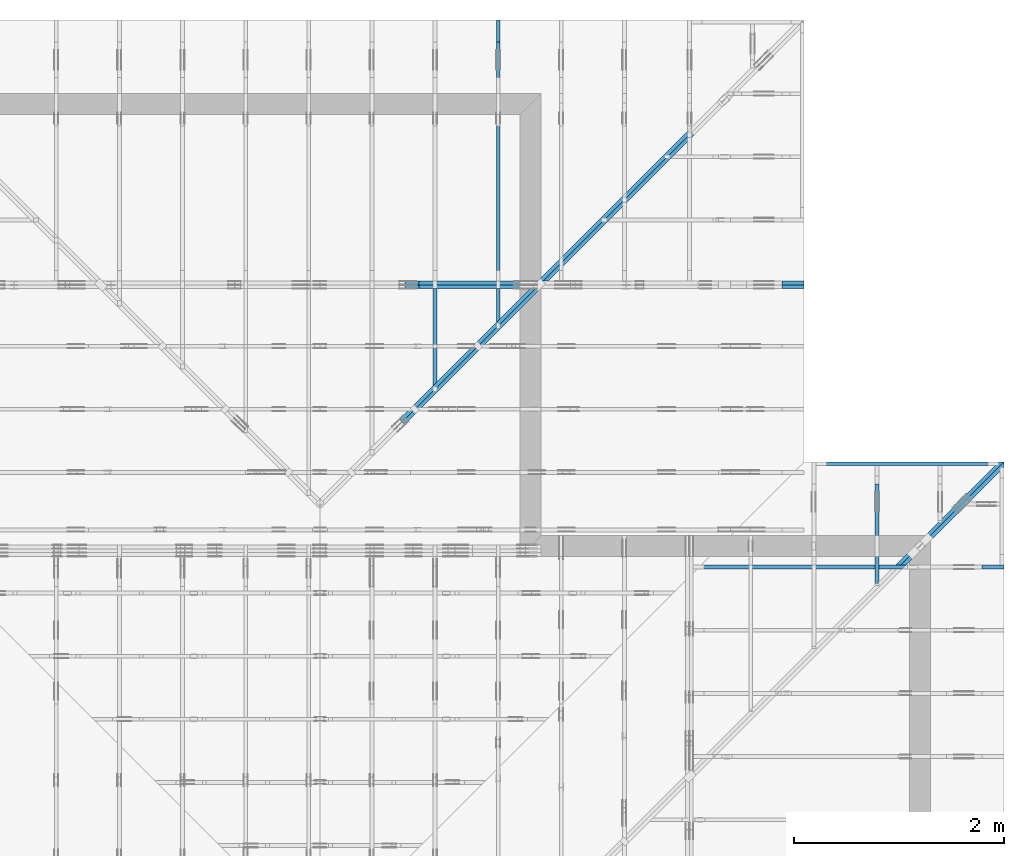
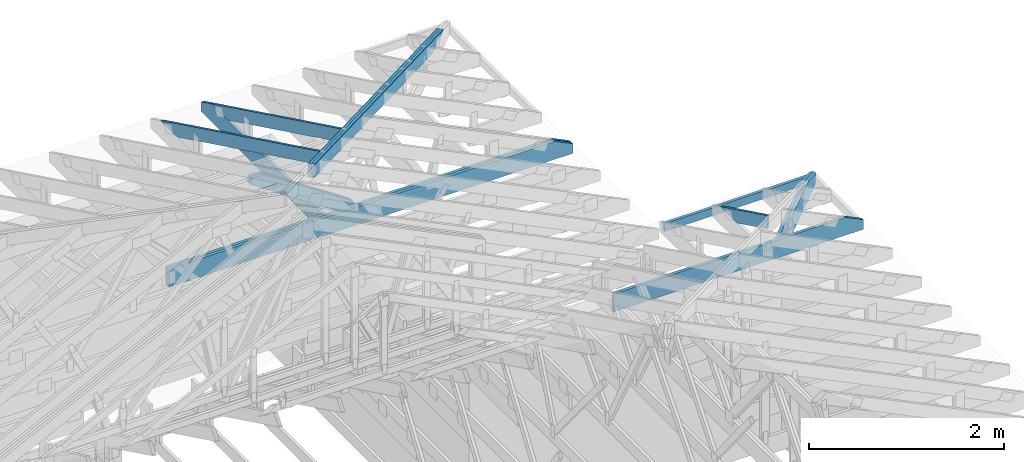
# One storey, part 39 of 159: 14 members, 8 elements without a shape of their own.
"""IFC2X3 building model written with IfcOpenShell, lengths in millimetres."""

from ifc_helpers import new_model, si_unit, frame, origin, origin_with_axes, origin_2d, place, context, project, spatial, faceted_brep, element, aggregate, save


model = new_model("IFC2X3")

# Units and contexts
model_context = context("Model", 3, precision=1e-05, world=origin())
plan_context = context("Plan", 2, precision=1e-05, world=origin_2d())
ifc_project = project(units=[si_unit("LENGTHUNIT", "METRE", prefix="MILLI"), si_unit("AREAUNIT", "SQUARE_METRE"), si_unit("VOLUMEUNIT", "CUBIC_METRE"), si_unit("SOLIDANGLEUNIT", "STERADIAN"), si_unit("PLANEANGLEUNIT", "RADIAN"), si_unit("MASSUNIT", "GRAM"), si_unit("TIMEUNIT", "SECOND"), si_unit("THERMODYNAMICTEMPERATUREUNIT", "DEGREE_CELSIUS"), si_unit("LUMINOUSINTENSITYUNIT", "LUMEN")], contexts=[model_context, plan_context])

# Site, building, storey
site_placement = place(None, origin_with_axes())
site = spatial("IfcSite", under=ifc_project, at=site_placement, CompositionType="ELEMENT")
building_placement = place(site_placement, origin_with_axes())
building = spatial("IfcBuilding", under=site, at=building_placement, Name="Plan 1", CompositionType="ELEMENT")
storey_placement = place(building_placement, origin_with_axes())
storey = spatial("IfcBuildingStorey", under=building, at=storey_placement, Name="Etasje 1", CompositionType="ELEMENT", Elevation=0.0)

# Assembly, member
assembly_1_placement = place(storey_placement, frame((19875.02226140475, 9663.999999999993, 1.1021457184401395e-15), z_axis=(-1.0, 1.836909530733566e-16, 6.123031769111886e-17), x_axis=(-1.836909530733566e-16, -1.0, 0.0)))
assembly_1 = element("IfcElementAssembly", 1, at=assembly_1_placement, inside=storey, Name="S22 (57)", AssemblyPlace="FACTORY", PredefinedType="TRUSS")
member_1_placement = place(assembly_1_placement, frame((240.0602225673573, 89.97847976245569, -36.000000217775856), z_axis=(0.0, 0.0, 1.0), x_axis=(0.898794046299167, 0.4383711467890774, 0.0)))
member_1 = element("IfcMember", 2, at=member_1_placement, Name="S22-O69", context=model_context, shape_type="Brep", body=[
    faceted_brep([(1071.3215394906892, 147.99999481755967, 36.00000324764591), (999.1371155399152, 7.034373084024992e-10, 36.000000217775664), (959.083445597556, 3.216400443761813e-07, -2.2737367544323206e-13), (1031.2678695483298, 147.99999513849625, 3.0298697311081924e-06), (5.444185688929792e-06, 147.99999999998226, 2.1777585601512328e-07), (5.444185688929792e-06, 147.9999999999822, 36.000000217775856), (1071.3215386473107, 147.99999999998215, 36.000000217775856), (1031.2678696714806, 147.9999999999822, 2.1777585601512328e-07), (4.652508783919984e-05, 148.00000000045958, 2.1777585601512897e-07), (1031.2678687907128, 148.00000000045958, 2.1777598230484175e-07), (959.083443436709, 0.0, 2.1777597346509114e-07), (303.4449928141504, 0.0, 2.177758931751899e-07), (303.4449717131313, 3.1174351988738636e-10, 2.1777585601512328e-07), (303.4449717131313, 3.1174351988738636e-10, 36.000000217775856), (7.105427357601002e-15, 148.000001541252, 36.000000217775856), (7.105427357601002e-15, 148.000001541252, 2.1777585601512328e-07), (999.1371146591276, 6.808444057420046e-10, 36.000000217775856), (303.4449569137662, 6.809721980975065e-10, 36.000000217775856), (303.4449569137662, 6.809699938060696e-10, 2.1777585601512328e-07), (959.0834456832976, 6.808495589471959e-10, 2.1777585601512328e-07), (1071.321540893919, 148.0000000007036, 36.000000217775856), (3.057897757230421e-05, 148.0000000007036, 36.000000217775856), (303.44497686804016, 3.1187141757982317e-10, 36.000000217775856), (999.137115539915, 3.1187141757982317e-10, 36.000000217775856)], [[[0, 1, 2, 3]], [[4, 5, 6, 7]], [[8, 9, 10, 11]], [[12, 13, 14, 15]], [[16, 17, 18, 19]], [[20, 21, 22, 23]]]),
])
aggregate(assembly_1, [member_1])

assembly_2_placement = place(storey_placement, frame((21100.012663101486, 8717.993668449257, 1.1021457184401395e-15), z_axis=(1.2246063538223773e-16, 1.0, 6.123031769111886e-17), x_axis=(-1.0, 1.2246063538223773e-16, 0.0)))
assembly_2 = element("IfcElementAssembly", 3, at=assembly_2_placement, inside=storey, Name="S20 (50)", AssemblyPlace="FACTORY", PredefinedType="TRUSS")
member_2_placement = place(assembly_2_placement, frame((2953.4710103785837, 223.0, -36.0), z_axis=(0.0, 0.0, 1.0), x_axis=(-1.0, 1.2246063538223773e-16, 0.0)))
member_2 = element("IfcMember", 4, at=member_2_placement, Name="S20-U10", context=model_context, shape_type="Brep", body=[
    faceted_brep([(2953.4710103785947, 223.00000000000037, 36.0), (6.311295874183998e-05, 223.00000000000037, 36.0), (6.311295874183998e-05, 0.0, 36.0), (2742.289720705732, 0.0, 36.0), (2953.4700660270973, 102.9995422363285, 36.0), (6.311295874183998e-05, 223.00000000000037, 7.728853028378678e-21), (2953.4710103785947, 223.00000000000037, 3.616839365139823e-13), (2953.4700660270973, 102.9995422363285, 3.6168382086809796e-13), (2742.289720705732, 0.0, 3.358225415998032e-13), (6.311295874183998e-05, 0.0, 7.728853028378678e-21), (0.0, 0.0, 0.0), (2.204291436880279e-15, -2.6993892992798474e-31, 36.0), (2.951301312711929e-14, 223.0, 36.0), (2.7308721690239013e-14, 223.0, -1.6721217048316832e-30), (2742.2897146949763, -5.037338112955833e-13, 5.172702487036636e-29), (2742.2897146949763, -5.01529519858703e-13, 36.0), (4.049083948919771e-31, 2.204291436880279e-15, 36.0), (0.0, 0.0, 0.0), (2953.4700660271083, 102.9995394088487, -7.573064690121713e-29), (2953.4700660271083, 102.9995394088487, 36.0), (2742.289714694976, 1.1368683772161603e-12, 36.0), (2742.289714694976, 1.1368683772161603e-12, -6.310887241768094e-29), (2953.4692552825763, 223.00000000000037, -1.0746508677980613e-19), (2953.4692552825763, 223.00000000000037, 36.0), (2953.4692552825763, 102.99953940884771, 36.0), (2953.4692552825763, 102.99953940884771, -4.9642145257273734e-20), (0.0, 223.0, 0.0), (0.0, 223.0, 36.0), (2953.4710103785947, 223.00000000000048, 36.0), (2953.4710103785947, 223.00000000000048, 6.310887241768095e-30)], [[[0, 1, 2, 3, 4]], [[5, 6, 7, 8, 9]], [[10, 11, 12, 13]], [[14, 15, 16, 17]], [[18, 19, 20, 21]], [[22, 23, 24, 25]], [[26, 27, 28, 29]]]),
])
aggregate(assembly_2, [member_2])

# Assembly, members
assembly_3_placement = place(storey_placement, frame((21074.556818978763, 9725.45584412271, 2.204291436880279e-15), z_axis=(-0.7071067811865471, 0.7071067811865479, 6.123031769111886e-17), x_axis=(-0.7071067811865479, -0.7071067811865471, 0.0)))
assembly_3 = element("IfcElementAssembly", 5, at=assembly_3_placement, inside=storey, Name="GR1 (36)", AssemblyPlace="FACTORY", PredefinedType="TRUSS")
member_3_placement = place(assembly_3_placement, frame((1424.7667236328134, 223.00000146033165, -36.00000106981066), z_axis=(0.0, 0.0, 1.0), x_axis=(-1.0, -3.216285744678249e-16, 0.0)))
member_3 = element("IfcMember", 6, at=member_3_placement, Name="GR1-U18.1", context=model_context, shape_type="Brep", body=[
    faceted_brep([(36.000052287264666, 1.4603316254347975e-06, 5.447731155072688e-11), (5.1217500185885e-05, 1.4603316458305926e-06, 36.00000106981078), (5.121750042391682e-05, 223.00000146033165, 36.000001069810665), (36.000052287264694, 223.00000146033165, 5.4580340247412096e-11), (1090.1112572721877, 1.460331445587017e-06, 1.0698106578388433e-06), (1090.1112572721877, 1.4603314477913084e-06, 36.00000106981066), (5.1217500185885e-05, 1.4603316480348747e-06, 36.00000106981066), (36.000051217500186, 1.460331639217709e-06, 1.0698106578388433e-06), (36.00005121751087, 223.00000146033165, 1.0698106622474326e-06), (1424.7667748503234, 223.00000146033165, 1.0698108323166879e-06), (1424.7660424284484, 115.41540673376913, 1.069810832316598e-06), (1090.1112572721984, 1.4603313047700794e-06, 1.0698107913345606e-06), (36.00005121751087, 1.4603313047700794e-06, 1.0698106622474326e-06), (1424.7667247027193, 223.00000146009992, 9.492850949754938e-11), (1388.7667236328564, 223.00000146009992, 36.00000106985442), (1388.7667236328564, 103.00000146009992, 36.00000106985442), (1424.7660368661059, 115.41540864085538, 0.0006878367084937054), (5.121751087244775e-05, 223.00000146033128, 36.00000106981066), (1388.7667748503234, 223.0000014603312, 36.00000106981066), (1424.7667748503234, 223.0000014603312, 1.0698106578388433e-06), (36.00005121751087, 223.00000146033128, 1.0698106578388433e-06), (1424.7660355374526, 115.41540889855611, 0.0006891652629761325), (1388.7667219993966, 103.00000089677076, 36.000002519755164), (1090.111266925373, 5.684341886080801e-13, 36.00000251975516), (1090.111266925373, 6.252776074688882e-13, 1.0698023231725529e-06), (1388.7667236328125, 223.00000146009992, 36.00000106981066), (0.0, 223.00000146009992, 36.00000106981066), (0.0, 1.4600999236336065e-06, 36.00000106981066), (1090.1112670898438, 1.4600999236336065e-06, 36.00000106981066), (1388.7667236328125, 103.00000146009992, 36.00000106981066)], [[[0, 1, 2, 3]], [[4, 5, 6, 7]], [[8, 9, 10, 11, 12]], [[13, 14, 15, 16]], [[17, 18, 19, 20]], [[21, 22, 23, 24]], [[25, 26, 27, 28, 29]]]),
])
member_4_placement = place(assembly_3_placement, frame((1388.7666724153025, 223.00000338441228, -72.00000132861265), z_axis=(0.0, 0.0, 1.0), x_axis=(-1.0, -3.216285744678249e-16, 0.0)))
member_4 = element("IfcMember", 7, at=member_4_placement, Name="GR1-U18.1", context=model_context, shape_type="Brep", body=[
    faceted_brep([(36.000001069760216, 3.384411907202513e-06, 2.5885243815082504e-07), (0.0, 3.384411911611096e-06, 36.000001328612655), (1.7763568394002505e-14, 223.0000033844119, 36.00000132861267), (36.00000106976019, 223.0000033844119, 2.5885248433610286e-07), (1054.1112060546875, 3.384412059040917e-06, 1.3286126545608568e-06), (1054.1112060546875, 3.384412085226026e-06, 36.000001328612655), (-4.108433177404207e-31, 3.384412278856718e-06, 36.000001328612655), (36.0, 3.384412246058735e-06, 1.3286126545608568e-06), (36.0, 223.00000338441225, 1.3286126589694396e-06), (1352.7667236328125, 223.00000338441225, 1.3286128202215292e-06), (1352.7667236328125, 103.00000338441227, 1.3286128202215292e-06), (1054.1112060546875, 3.3844119400328054e-06, 1.3286127836479848e-06), (36.0, 3.3844119400328054e-06, 1.3286126589694396e-06), (1352.7666710867957, 223.0000055491984, 0.0), (1388.7666724153178, 223.0000055491984, 36.00000132861453), (1388.765984319942, 115.41541082263589, 35.99931323323881), (1352.7666710867957, 103.00000364184973, 1.1368683772161603e-13), (-1.349694699451629e-31, 223.0000033844115, 36.000001328612655), (1388.7667236328125, 223.00000338441143, 36.000001328612655), (1352.7667236328125, 223.00000338441143, 1.3286126545608568e-06), (36.0, 223.0000033844115, 1.3286126545608568e-06), (1388.7659859534638, 115.41541138600286, 35.999314683104835), (1054.1112101288768, -1.1368683772161603e-13, 36.000001328612655), (1054.1112101288768, -1.7053025658242404e-13, 1.3286126545608568e-06), (1352.7666724154083, 103.00000338421711, 1.3286126545608568e-06), (1388.7667236328125, 223.00000338439727, 36.000001328612655), (0.0, 223.00000338439727, 36.000001328612655), (0.0, 3.384411911611096e-06, 36.000001328612655), (1054.1112060546875, 3.384411911611096e-06, 36.000001328612655), (1388.7659912109375, 115.4154086578494, 36.000001328612655)], [[[0, 1, 2, 3]], [[4, 5, 6, 7]], [[8, 9, 10, 11, 12]], [[13, 14, 15, 16]], [[17, 18, 19, 20]], [[21, 22, 23, 24]], [[25, 26, 27, 28, 29]]]),
])
aggregate(assembly_3, [member_3, member_4])

assembly_4_placement = place(storey_placement, frame((19200.01266310149, 11417.999978540158, 0.0), z_axis=(1.2246063538223773e-16, 1.0, 6.123031769111886e-17), x_axis=(-1.0, 1.2246063538223773e-16, 0.0)))
assembly_4 = element("IfcElementAssembly", 8, at=assembly_4_placement, inside=storey, Name="V9 (1)", AssemblyPlace="FACTORY", PredefinedType="TRUSS")
member_5_placement = place(assembly_4_placement, frame((4780.0, 223.00000000000034, -36.0), z_axis=(0.0, 0.0, 1.0), x_axis=(-1.0, 1.2246063538223773e-16, 0.0)))
member_5 = element("IfcMember", 9, at=member_5_placement, Name="V9-U5", context=model_context, shape_type="Brep", body=[
    faceted_brep([(4780.0, 223.00000000000094, 36.0), (0.0, 223.00000000000094, 36.0), (0.0, 3.410605131648481e-13, 36.0), (4568.818710327148, 3.410605131648481e-13, 36.0), (4779.999055648514, 102.99954223632906, 36.0), (0.0, 223.00000000000094, 0.0), (4780.0, 223.00000000000094, 5.853618371270963e-13), (4779.999055648514, 102.99954223632906, 5.853617214812133e-13), (4568.818710327148, 3.410605131648481e-13, 5.595004422129185e-13), (0.0, 3.410605131648481e-13, 0.0), (0.0, 0.0, 0.0), (2.204291436880279e-15, -2.6993892992798474e-31, 36.0), (2.951301312711929e-14, 223.0, 36.0), (2.7308721690239013e-14, 223.0, -1.6721217048316832e-30), (4568.8187043163925, -8.392506622152563e-13, 1.0707623419786783e-28), (4568.8187043163925, -8.37046370778376e-13, 36.0), (4.049083948919771e-31, 2.204291436880279e-15, 36.0), (0.0, 0.0, 0.0), (4779.999055648511, 102.99953940909359, 1.262177448353619e-28), (4779.999055648511, 102.99953940909359, 36.0), (4568.8187043163925, -1.3642420526593924e-12, 36.0), (4568.8187043163925, -1.3642420526593924e-12, 1.262177448353619e-28), (4779.998244790859, 223.00000000000094, -1.074720133572072e-19), (4779.998244790859, 223.00000000000094, 36.0), (4779.998244790859, 102.99953940909566, 36.0), (4779.998244790859, 102.99953940909566, -4.9649071632726417e-20), (0.0, 223.0, 0.0), (0.0, 223.0, 36.0), (4780.0, 223.00000000000077, 36.0), (4780.0, 223.00000000000077, -9.466330862652142e-30)], [[[0, 1, 2, 3, 4]], [[5, 6, 7, 8, 9]], [[10, 11, 12, 13]], [[14, 15, 16, 17]], [[18, 19, 20, 21]], [[22, 23, 24, 25]], [[26, 27, 28, 29]]]),
])
member_6_placement = place(assembly_4_placement, frame((4780.0, 223.00000000000034, -72.0), z_axis=(0.0, 0.0, 1.0), x_axis=(-1.0, 1.2246063538223773e-16, 0.0)))
member_6 = element("IfcMember", 10, at=member_6_placement, Name="V9-U5", context=model_context, shape_type="Brep", body=[
    faceted_brep([(4780.0, 223.00000000000094, 36.0), (0.0, 223.00000000000094, 36.0), (0.0, 3.410605131648481e-13, 36.0), (4568.818710327148, 3.410605131648481e-13, 36.0), (4779.999055648514, 102.99954223632906, 36.0), (0.0, 223.00000000000094, 0.0), (4780.0, 223.00000000000094, 5.853618371270963e-13), (4779.999055648514, 102.99954223632906, 5.853617214812133e-13), (4568.818710327148, 3.410605131648481e-13, 5.595004422129185e-13), (0.0, 3.410605131648481e-13, 0.0), (0.0, 0.0, 0.0), (2.204291436880279e-15, -2.6993892992798474e-31, 36.0), (2.951301312711929e-14, 223.0, 36.0), (2.7308721690239013e-14, 223.0, -1.6721217048316832e-30), (4568.8187043163925, -8.392506622152563e-13, 1.0707623419786783e-28), (4568.8187043163925, -8.37046370778376e-13, 36.0), (4.049083948919771e-31, 2.204291436880279e-15, 36.0), (0.0, 0.0, 0.0), (4779.999055648511, 102.99953940909359, 1.262177448353619e-28), (4779.999055648511, 102.99953940909359, 36.0), (4568.8187043163925, -1.3642420526593924e-12, 36.0), (4568.8187043163925, -1.3642420526593924e-12, 1.262177448353619e-28), (4779.998244790859, 223.00000000000094, -1.074720133572072e-19), (4779.998244790859, 223.00000000000094, 36.0), (4779.998244790859, 102.99953940909566, 36.0), (4779.998244790859, 102.99953940909566, -4.9649071632726417e-20), (0.0, 223.0, 0.0), (0.0, 223.0, 36.0), (4780.0, 223.00000000000077, 36.0), (4780.0, 223.00000000000077, -9.466330862652142e-30)], [[[0, 1, 2, 3, 4]], [[5, 6, 7, 8, 9]], [[10, 11, 12, 13]], [[14, 15, 16, 17]], [[18, 19, 20, 21]], [[22, 23, 24, 25]], [[26, 27, 28, 29]]]),
])
member_7_placement = place(assembly_4_placement, frame((3751.8400175874117, 1079.4829737396972, -36.0), z_axis=(0.0, 0.0, 1.0), x_axis=(-0.8323764395198876, -0.5542106665629911, 0.0)))
member_7 = element("IfcMember", 11, at=member_7_placement, Name="V9-D5", context=model_context, shape_type="Brep", body=[
    faceted_brep([(1323.127308669783, 147.9999915965634, 36.0), (21.850259557763366, 147.9999915965634, 36.0), (5.4844066198711516e-05, 74.00000223351094, 36.0), (111.1416151258677, 2.424019226054952e-05, 36.0), (1390.091334237321, 2.424019226054952e-05, 36.0), (1434.2688689515849, 74.00000223351094, 36.0), (21.850259557763366, 147.9999915965634, 2.6757966687105146e-15), (1323.127308669783, 147.9999915965634, 1.620310109112918e-13), (1434.2688689515849, 74.00000223351094, 1.7564147700077452e-13), (1390.091334237321, 2.424019226054952e-05, 1.7023146803004493e-13), (111.1416151258677, 2.424019226054952e-05, 1.3610472805721883e-14), (5.4844066198711516e-05, 74.00000223351094, 6.7162391936397196e-21), (-4.263256414560601e-14, 74.00001360324839, 2.7610131682735413e-30), (-3.907985046680551e-14, 74.00001360324839, 36.0), (21.850228666201396, 148.0000136032498, 36.0), (21.850228666201396, 148.0000136032498, 5.9164567891575885e-30), (111.1415933339326, 1.3603249236382453e-05, 2.3665827156630354e-30), (111.1415933339326, 1.3603249236382453e-05, 36.0), (-7.105427357601002e-15, 74.00001360324836, 36.0), (-7.105427357601002e-15, 74.00001360324836, 0.0), (1390.0913268414797, 1.3603249016562389e-05, 1.5634990246897296e-29), (1390.0913268414797, 1.360324901876668e-05, 36.0), (111.14159333393263, 1.3603249253698177e-05, 36.0), (111.14159333393263, 1.3603249251493885e-05, 1.2500600952350601e-30), (1434.2688689515771, 74.00001360325018, -1.262177448353619e-29), (1434.2688689515771, 74.00001360325018, 36.0), (1390.0913268414797, 1.3603249612970103e-05, 36.0), (1390.0913268414797, 1.3603249612970103e-05, -2.524354896707238e-29), (1323.1272756176472, 148.0000136032486, 1.262177448353619e-29), (1323.1272756176472, 148.0000136032486, 36.0), (1434.2688689515774, 74.00001360325007, 36.0), (1434.2688689515774, 74.00001360325007, 1.262177448353619e-29), (21.850228666201474, 148.00001360324973, 0.0), (21.850228666201474, 148.00001360324973, 36.0), (1323.1272756176472, 148.0000136032485, 36.0), (1323.1272756176472, 148.0000136032485, 7.888609052210118e-30)], [[[0, 1, 2, 3, 4, 5]], [[6, 7, 8, 9, 10, 11]], [[12, 13, 14, 15]], [[16, 17, 18, 19]], [[20, 21, 22, 23]], [[24, 25, 26, 27]], [[28, 29, 30, 31]], [[32, 33, 34, 35]]]),
])
member_8_placement = place(assembly_4_placement, frame((3751.8400175874117, 1079.4829737396972, -72.0), z_axis=(0.0, 0.0, 1.0), x_axis=(-0.8323764395198876, -0.5542106665629911, 0.0)))
member_8 = element("IfcMember", 12, at=member_8_placement, Name="V9-D5", context=model_context, shape_type="Brep", body=[
    faceted_brep([(1323.127308669783, 147.9999915965634, 36.0), (21.850259557763366, 147.9999915965634, 36.0), (5.4844066198711516e-05, 74.00000223351094, 36.0), (111.1416151258677, 2.424019226054952e-05, 36.0), (1390.091334237321, 2.424019226054952e-05, 36.0), (1434.2688689515849, 74.00000223351094, 36.0), (21.850259557763366, 147.9999915965634, 2.6757966687105146e-15), (1323.127308669783, 147.9999915965634, 1.620310109112918e-13), (1434.2688689515849, 74.00000223351094, 1.7564147700077452e-13), (1390.091334237321, 2.424019226054952e-05, 1.7023146803004493e-13), (111.1416151258677, 2.424019226054952e-05, 1.3610472805721883e-14), (5.4844066198711516e-05, 74.00000223351094, 6.7162391936397196e-21), (-4.263256414560601e-14, 74.00001360324839, 2.7610131682735413e-30), (-3.907985046680551e-14, 74.00001360324839, 36.0), (21.850228666201396, 148.0000136032498, 36.0), (21.850228666201396, 148.0000136032498, 5.9164567891575885e-30), (111.1415933339326, 1.3603249236382453e-05, 2.3665827156630354e-30), (111.1415933339326, 1.3603249236382453e-05, 36.0), (-7.105427357601002e-15, 74.00001360324836, 36.0), (-7.105427357601002e-15, 74.00001360324836, 0.0), (1390.0913268414797, 1.3603249016562389e-05, 1.5634990246897296e-29), (1390.0913268414797, 1.360324901876668e-05, 36.0), (111.14159333393263, 1.3603249253698177e-05, 36.0), (111.14159333393263, 1.3603249251493885e-05, 1.2500600952350601e-30), (1434.2688689515771, 74.00001360325018, -1.262177448353619e-29), (1434.2688689515771, 74.00001360325018, 36.0), (1390.0913268414797, 1.3603249612970103e-05, 36.0), (1390.0913268414797, 1.3603249612970103e-05, -2.524354896707238e-29), (1323.1272756176472, 148.0000136032486, 1.262177448353619e-29), (1323.1272756176472, 148.0000136032486, 36.0), (1434.2688689515774, 74.00001360325007, 36.0), (1434.2688689515774, 74.00001360325007, 1.262177448353619e-29), (21.850228666201474, 148.00001360324973, 0.0), (21.850228666201474, 148.00001360324973, 36.0), (1323.1272756176472, 148.0000136032485, 36.0), (1323.1272756176472, 148.0000136032485, 7.888609052210118e-30)], [[[0, 1, 2, 3, 4, 5]], [[6, 7, 8, 9, 10, 11]], [[12, 13, 14, 15]], [[16, 17, 18, 19]], [[20, 21, 22, 23]], [[24, 25, 26, 27]], [[28, 29, 30, 31]], [[32, 33, 34, 35]]]),
])
aggregate(assembly_4, [member_5, member_6, member_7, member_8])

assembly_5_placement = place(storey_placement, frame((19174.556818978774, 13925.455822662876, 2.204291436880279e-15), z_axis=(-0.7071067811865465, 0.7071067811865486, 6.123031769111886e-17), x_axis=(-0.7071067811865486, -0.7071067811865465, 0.0)))
assembly_5 = element("IfcElementAssembly", 13, at=assembly_5_placement, inside=storey, Name="GR3 (58)", AssemblyPlace="FACTORY", PredefinedType="TRUSS")
member_9_placement = place(assembly_5_placement, frame((364.9085270187576, 83.08695328990643, -36.0), z_axis=(0.0, 0.0, 1.0), x_axis=(0.9453579955214153, 0.326034139782526, 0.0)))
member_9 = element("IfcMember", 14, at=member_9_placement, Name="GR3-O2", context=model_context, shape_type="Brep", body=[
    faceted_brep([(5380.000178702135, 148.00005689174122, 36.0), (3.8457324080809485e-06, 148.00005689174122, 36.0), (429.13598774094555, 6.780209196222131e-05, 36.0), (5380.0000289715945, 6.780209196222131e-05, 36.0), (3.8457324080809485e-06, 148.00005689174122, 4.709508342036561e-22), (5380.000178702135, 148.00005689174122, 6.588382402404159e-13), (5380.0000289715945, 6.780209196222131e-05, 6.588382219043188e-13), (429.13598774094555, 6.780209196222131e-05, 5.2552265724140374e-14), (429.13598995963724, 6.703691178699955e-05, -7.561007189748099e-30), (429.13598995963724, 6.703691178699955e-05, 36.0), (-7.105427357601002e-15, 148.0000670359, 36.0), (-7.105427357601002e-15, 148.0000670359, 1.4869126587626424e-31), (5379.999999999999, 6.703622476456266e-05, 2.167167791481066e-29), (5379.999999999999, 6.703622476676695e-05, 36.0), (429.1359899596373, 6.703691164728521e-05, 36.0), (429.1359899596373, 6.703691164508092e-05, 1.7286424957090684e-30), (5379.999999999999, 148.00006703622512, -5.048709793414476e-29), (5379.999999999999, 148.00006703622512, 36.0), (5379.999999999999, 6.703622511849971e-05, 36.0), (5379.999999999999, 6.703622511849971e-05, 0.0), (0.0, 148.00006703590003, 0.0), (0.0, 148.00006703590003, 36.0), (5380.0, 148.00006703622464, 36.0), (5380.0, 148.00006703622464, -2.8398992587956425e-29)], [[[0, 1, 2, 3]], [[4, 5, 6, 7]], [[8, 9, 10, 11]], [[12, 13, 14, 15]], [[16, 17, 18, 19]], [[20, 21, 22, 23]]]),
])
member_10_placement = place(assembly_5_placement, frame((364.9085270187576, 83.08695328990643, -72.0), z_axis=(0.0, 0.0, 1.0), x_axis=(0.9453579955214153, 0.326034139782526, 0.0)))
member_10 = element("IfcMember", 15, at=member_10_placement, Name="GR3-O2", context=model_context, shape_type="Brep", body=[
    faceted_brep([(5380.000178702135, 148.00005689174122, 36.0), (3.8457324080809485e-06, 148.00005689174122, 36.0), (429.13598774094555, 6.780209196222131e-05, 36.0), (5380.0000289715945, 6.780209196222131e-05, 36.0), (3.8457324080809485e-06, 148.00005689174122, 4.709508342036561e-22), (5380.000178702135, 148.00005689174122, 6.588382402404159e-13), (5380.0000289715945, 6.780209196222131e-05, 6.588382219043188e-13), (429.13598774094555, 6.780209196222131e-05, 5.2552265724140374e-14), (429.13598995963724, 6.703691178699955e-05, -7.561007189748099e-30), (429.13598995963724, 6.703691178699955e-05, 36.0), (-7.105427357601002e-15, 148.0000670359, 36.0), (-7.105427357601002e-15, 148.0000670359, 1.4869126587626424e-31), (5379.999999999999, 6.703622476456266e-05, 2.167167791481066e-29), (5379.999999999999, 6.703622476676695e-05, 36.0), (429.1359899596373, 6.703691164728521e-05, 36.0), (429.1359899596373, 6.703691164508092e-05, 1.7286424957090684e-30), (5379.999999999999, 148.00006703622512, -5.048709793414476e-29), (5379.999999999999, 148.00006703622512, 36.0), (5379.999999999999, 6.703622511849971e-05, 36.0), (5379.999999999999, 6.703622511849971e-05, 0.0), (0.0, 148.00006703590003, 0.0), (0.0, 148.00006703590003, 36.0), (5380.0, 148.00006703622464, 36.0), (5380.0, 148.00006703622464, -2.8398992587956425e-29)], [[[0, 1, 2, 3]], [[4, 5, 6, 7]], [[8, 9, 10, 11]], [[12, 13, 14, 15]], [[16, 17, 18, 19]], [[20, 21, 22, 23]]]),
])
aggregate(assembly_5, [member_9, member_10])

assembly_6_placement = place(storey_placement, frame((16275.022261404762, 13899.999978540158, 1.1021457184401395e-15), z_axis=(-1.0, 1.836909530733566e-16, 6.123031769111886e-17), x_axis=(-1.836909530733566e-16, -1.0, 0.0)))
assembly_6 = element("IfcElementAssembly", 16, at=assembly_6_placement, inside=storey, Name="S39 (62)", AssemblyPlace="FACTORY", PredefinedType="TRUSS")
member_11_placement = place(assembly_6_placement, frame((276.0601905787963, 89.97846416003, -36.000000217594575), z_axis=(0.0, 0.0, 1.0), x_axis=(0.8987940462991671, 0.4383711467890776, 0.0)))
member_11 = element("IfcMember", 17, at=member_11_placement, Name="S39-O38", context=model_context, shape_type="Brep", body=[
    faceted_brep([(2962.7448738897137, 147.9999948172224, 36.00000324780444), (2890.5604499386636, 5.007905201637186e-10, 36.000000217594106), (2850.5067799961416, 3.2167429253604496e-07, -4.547473508864641e-13), (2922.6912039471918, 147.999995138396, 3.0302098821266554e-06), (-1.262177448353619e-29, 148.00000000145343, 2.1759456814152142e-07), (7.888609052210118e-31, 148.00000000145366, 36.00000021759457), (2962.7448730468755, 148.00000000145346, 36.00000021759457), (2922.6912040710454, 148.00000000145326, 2.1759456814152142e-07), (4.108038916683654e-05, 148.0000000009652, 2.1759456814152648e-07), (2922.6912031897646, 148.0000000009652, 2.1759492605614323e-07), (2850.506777835761, 1.4468923836830072e-09, 2.1759491721639262e-07), (303.44510943976474, 1.4468923836830072e-09, 2.1759460530160237e-07), (303.4450073055866, 7.105427357601002e-14, 2.1759456814152145e-07), (303.4450073055866, 7.105427357601002e-14, 36.00000021759457), (3.559245546824741e-05, 148.00000154094027, 36.00000021759457), (3.559245546824741e-05, 148.00000154094027, 2.1759456814152145e-07), (2890.5604490573824, 4.922356196411148e-10, 36.00000021759457), (303.445012503427, 4.927108493413662e-10, 36.00000021759457), (303.445012503427, 4.929404596174711e-10, 2.1759456814152145e-07), (2850.5067800815523, 4.92472587413848e-10, 2.1759456814152145e-07), (2962.7448752926675, 148.00000000050102, 36.00000021759457), (0.00014720428805503616, 148.00000000050102, 36.00000021759457), (303.4449714230382, 0.0, 36.00000021759457), (2890.560449938663, 0.0, 36.00000021759457)], [[[0, 1, 2, 3]], [[4, 5, 6, 7]], [[8, 9, 10, 11]], [[12, 13, 14, 15]], [[16, 17, 18, 19]], [[20, 21, 22, 23]]]),
])
member_12_placement = place(assembly_6_placement, frame((2482.0, 223.00000000093004, -36.0), z_axis=(0.0, 0.0, 1.0), x_axis=(-1.0, 5.665498452323003e-16, 0.0)))
member_12 = element("IfcMember", 18, at=member_12_placement, Name="S39-U12", context=model_context, shape_type="Brep", body=[
    faceted_brep([(2482.0, 223.00000000093144, 36.0), (0.0, 223.00000000093144, 36.0), (0.0, 9.300435976911103e-10, 36.0), (2270.8187103271484, 9.300435976911103e-10, 36.0), (2482.0, 103.00000000093144, 36.0), (0.0, 223.00000000093144, 0.0), (2482.0, 223.00000000093144, 3.0394729701871404e-13), (2482.0, 103.00000000093144, 3.0394729701871404e-13), (2270.8187103271484, 9.300435976911103e-10, 2.7808590210453623e-13), (0.0, 9.300435976911103e-10, 0.0), (1.8189894035459704e-12, 9.300435976911103e-10, -6.97286115848029e-42), (1.8211936949828507e-12, 9.300435976911103e-10, 36.0), (1.8485024166730897e-12, 223.00000000093004, 36.0), (1.8462981252362094e-12, 223.00000000093004, -1.672121704838656e-30), (2270.8187043163925, -1.6082071276784428e-13, 9.847103334080383e-30), (2270.8187043163925, -1.58616421330964e-13, 36.0), (1.8189894035458573e-12, 9.300458019825472e-10, 36.0), (1.8189894035458565e-12, 9.300435976911103e-10, 0.0), (2482.0000000000005, 103.00000000087255, 4.487866375234114e-29), (2482.0000000000005, 103.00000000087255, 36.0), (2270.8187043163925, -6.821210263296962e-13, 36.0), (2270.8187043163925, -6.821210263296962e-13, 3.1532860652502367e-29), (2482.0, 223.00000000093144, 0.0), (2482.0, 223.00000000093144, 36.0), (2482.0, 103.00000000087323, 36.0), (2482.0, 103.00000000087323, 0.0), (1.8189894035458565e-12, 223.00000000093004, 0.0), (1.8189894035458565e-12, 223.00000000093004, 36.0), (2482.0, 223.0000000009321, 36.0), (2482.0, 223.0000000009321, 4.1020767071492614e-29)], [[[0, 1, 2, 3, 4]], [[5, 6, 7, 8, 9]], [[10, 11, 12, 13]], [[14, 15, 16, 17]], [[18, 19, 20, 21]], [[22, 23, 24, 25]], [[26, 27, 28, 29]]]),
])
aggregate(assembly_6, [member_11, member_12])

# Assembly, member
assembly_7_placement = place(storey_placement, frame((15675.022261404756, 13899.999978540158, 1.1021457184401395e-15), z_axis=(-1.0, 1.836909530733566e-16, 6.123031769111886e-17), x_axis=(-1.836909530733566e-16, -1.0, 0.0)))
assembly_7 = element("IfcElementAssembly", 19, at=assembly_7_placement, inside=storey, Name="S38 (64)", AssemblyPlace="FACTORY", PredefinedType="TRUSS")
member_13_placement = place(assembly_7_placement, frame((276.0601241290889, 89.9784317495837, -36.00000021757932), z_axis=(0.0, 0.0, 1.0), x_axis=(0.8987940462991668, 0.4383711467890777, 0.0)))
member_13 = element("IfcMember", 20, at=member_13_placement, Name="S38-O27", context=model_context, shape_type="Brep", body=[
    faceted_brep([(3630.3061121070277, 147.99999481741315, 36.000003247762834), (3558.121688155953, 7.0349415182136e-10, 36.00000021757978), (3518.0680182134165, 3.2188404475164134e-07, 4.547473508864641e-13), (3590.252442164491, 147.99999513859325, 3.0301832794066286e-06), (0.00020306022406657576, 147.9999999999816, 2.1757931989441204e-07), (0.00020306022406657576, 147.99999999998184, 36.00000021757932), (3630.3061112633486, 147.9999999999816, 36.00000021757932), (3590.2524422875185, 147.99999999998138, 2.1757931989441204e-07), (0.0, 148.00000000164675, 2.1757931989441204e-07), (3590.25244140625, 148.00000000164675, 2.175797595590072e-07), (3518.068016052246, 0.0, 2.175797507192566e-07), (303.4450683593752, 0.0, 2.1757935705448793e-07), (303.44508123799244, 6.815383812863729e-10, 2.1757931989441204e-07), (303.44508123799244, 6.815383812863729e-10, 36.00000021757932), (0.00010952486134385708, 148.00000154162205, 36.00000021757932), (0.00010952486134385708, 148.00000154162205, 2.1757931989441204e-07), (3558.1216872746754, 7.024563120485282e-10, 36.00000021757932), (303.444971423846, 7.030541667164085e-10, 36.00000021757932), (303.444971423846, 7.028281414632072e-10, 2.1757931989441204e-07), (3518.0680182988453, 7.022376442919551e-10, 2.1757931989441204e-07), (3630.306113509956, 148.0000000007035, 36.00000021757932), (0.00010612470288151599, 148.0000000007035, 36.00000021757932), (303.44517448407794, 6.817799658165313e-10, 36.00000021757932), (3558.121688155953, 6.817799658165313e-10, 36.00000021757932)], [[[0, 1, 2, 3]], [[4, 5, 6, 7]], [[8, 9, 10, 11]], [[12, 13, 14, 15]], [[16, 17, 18, 19]], [[20, 21, 22, 23]]]),
])
aggregate(assembly_7, [member_13])

assembly_8_placement = place(storey_placement, frame((19311.02226140475, 9663.99999999999, 2.204291436880279e-15), z_axis=(0.0, -1.0, 6.123031769111886e-17), x_axis=(1.0, 0.0, 0.0)))
assembly_8 = element("IfcElementAssembly", 21, at=assembly_8_placement, inside=storey, Name="uu3 (1)", AssemblyPlace="FACTORY", PredefinedType="TRUSS")
member_14_placement = place(assembly_8_placement, frame((1738.0787353515625, 98.00000236466228, -36.000001069702904), z_axis=(0.0, 0.0, 1.0), x_axis=(-1.0, 1.2246063538223773e-16, 0.0)))
member_14 = element("IfcMember", 22, at=member_14_placement, Name="uu3-U49", context=model_context, shape_type="Brep", body=[
    faceted_brep([(2.0830544875755296e-05, 2.3646622517535772e-06, -4.893329326265648e-14), (36.00002190036229, 2.3646622793194183e-06, 36.00000106970279), (36.00002190036231, 98.00000236466228, 36.00000106970288), (2.0830544845340552e-05, 98.00000236466225, -4.3076927794130984e-15), (1738.0787572519246, 2.3646619742609297e-06, 1.0697029040329653e-06), (1738.0787572519246, 2.3646619604780096e-06, 36.000001069702904), (36.00002190036207, 2.3646622731344748e-06, 36.000001069702904), (2.190036207139201e-05, 2.364662293530269e-06, 1.0697029040329653e-06), (2.1900250430917367e-05, 98.00000236466228, 1.0697029040329653e-06), (36.00002190025043, 98.00000236466228, 36.000001069702904), (1738.078757251813, 98.00000236466217, 36.000001069702904), (1738.078757251813, 98.00000236466218, 1.0697029040329653e-06), (1738.0787353515625, 98.0000023463934, 2.0346711266938655e-06), (1738.0787353515625, 98.0000023463934, 36.000001069702904), (1738.0787353515625, 0.0, 36.00000289661156), (1738.0787353515625, 0.0, 3.532736215561272e-06), (1738.0787572519248, 98.00000236466249, 36.000001069702904), (36.0000219003623, 98.00000236466249, 36.000001069702904), (36.00002190036207, 2.3646622793194183e-06, 36.000001069702904), (1738.0787572519248, 2.3646622793194183e-06, 36.000001069702904), (0.0, 98.00000236466228, 1.0697029040329653e-06), (1738.0787353515625, 98.00000236466228, 1.0697031168791916e-06), (1738.0787353515625, 2.364662492482239e-06, 1.0697031168791916e-06), (0.0, 2.364662492482239e-06, 1.0697029040329653e-06)], [[[0, 1, 2, 3]], [[4, 5, 6, 7]], [[8, 9, 10, 11]], [[12, 13, 14, 15]], [[16, 17, 18, 19]], [[20, 21, 22, 23]]]),
])
aggregate(assembly_8, [member_14])

save(model, "model.ifc")
